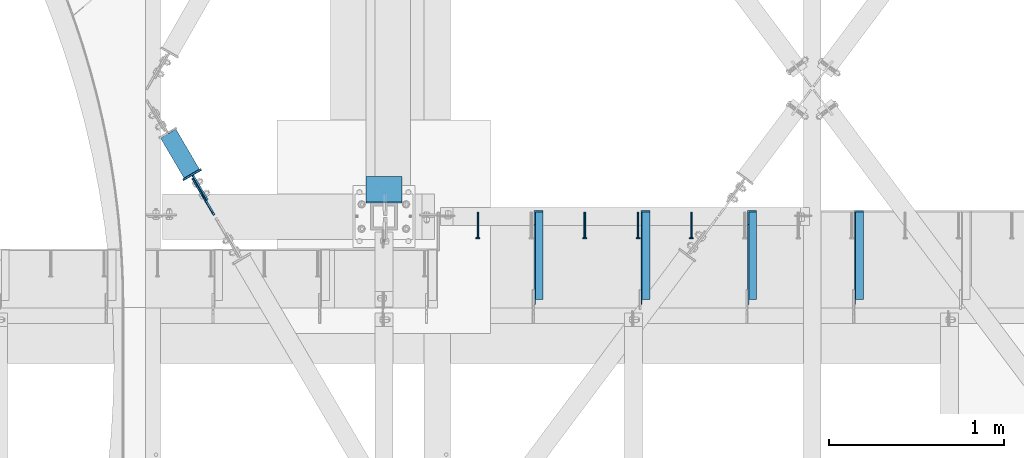
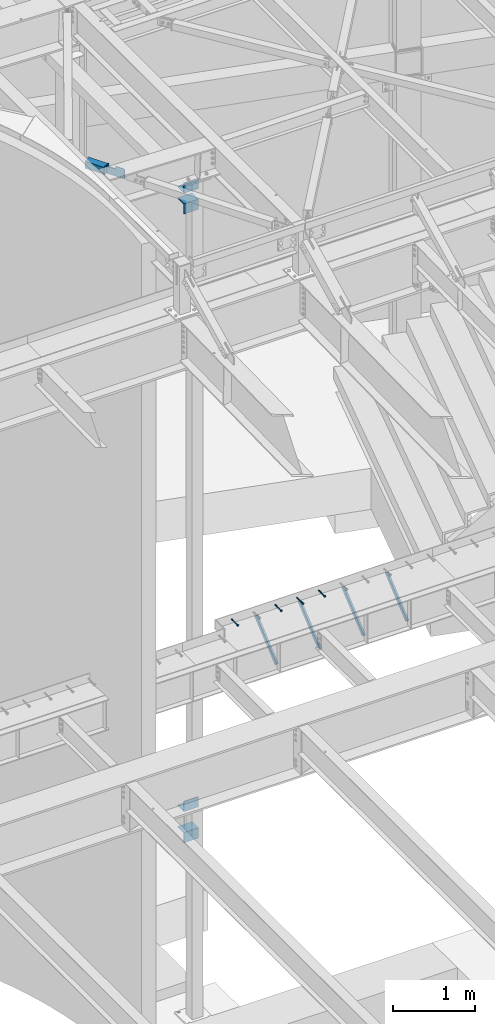
# One storey, part 1361 of 1763: 9 beams, 7 members, 8 elements without a shape of their own.
"""IFC2X3 building model written with IfcOpenShell, lengths in millimetres."""

import ifcopenshell
import ifcopenshell.guid

model = None  # the IFC model being written
_history = None  # IfcOwnerHistory: only IFC2X3 demands one
_inside = {}  # id of a spatial element -> (the spatial element, [elements in it])
_under = {}  # id of a project, library or spatial element -> (it, [spatial elements below it])
_declared = {}  # id of a project -> (the project, [libraries it declares])
_typed = {}  # id of a type object -> (the type object, [elements of that type])
_made_of = {}  # id of a material, layer set ... -> (it, [elements and type objects made of it])


def new_model(schema):
    """Start an empty IFC model of exactly this schema.

    Asked for "IFC4X3", IfcOpenShell would pick the latest addendum, in which some entities
    have other attributes; the version numbers below select the first issue.
    IFC2X3 requires an IfcOwnerHistory on every rooted entity: one is made here for all.
    """
    global model, _history
    if schema == "IFC4X3":
        model = ifcopenshell.file(schema_version=(4, 3, 0, 0))
    else:
        model = ifcopenshell.file(schema=schema)
    _inside.clear()
    _under.clear()
    _declared.clear()
    _typed.clear()
    _made_of.clear()
    _history = None
    if model.schema == "IFC2X3":
        org = make("IfcOrganization", Name="unknown")
        user = make(
            "IfcPersonAndOrganization",
            ThePerson=make("IfcPerson", FamilyName="unknown"),
            TheOrganization=org,
        )
        app = make(
            "IfcApplication",
            ApplicationDeveloper=org,
            Version="unknown",
            ApplicationFullName="unknown",
            ApplicationIdentifier="unknown",
        )
        _history = make(
            "IfcOwnerHistory",
            OwningUser=user,
            OwningApplication=app,
            ChangeAction="ADDED",
            CreationDate=0,
        )
    return model


def make(cls, **values):
    """One entity of the class cls with the attributes given. An attribute that is None is left unset."""
    return model.create_entity(
        cls, **{name: value for name, value in values.items() if value is not None}
    )


def rooted(cls, **values):
    """An entity with a GlobalId (a new one), such as an element, a storey or a relation."""
    return make(cls, GlobalId=ifcopenshell.guid.new(), OwnerHistory=_history, **values)


def si_unit(unit_type, name, prefix=None):
    """IfcSIUnit, for example si_unit("LENGTHUNIT", "METRE", prefix="MILLI")."""
    return make("IfcSIUnit", UnitType=unit_type, Prefix=prefix, Name=name)


def assignment(units):
    """IfcUnitAssignment: the units of a project."""
    return None if units is None else make("IfcUnitAssignment", Units=units)


def point(xyz):
    """IfcCartesianPoint."""
    return None if xyz is None else make("IfcCartesianPoint", Coordinates=xyz)


def direction(xyz):
    """IfcDirection."""
    return None if xyz is None else make("IfcDirection", DirectionRatios=xyz)


def frame(location, z_axis=None, x_axis=None):
    """IfcAxis2Placement3D, a coordinate frame: its origin and axes. An axis left out is left unset."""
    return make(
        "IfcAxis2Placement3D",
        Location=point(location),
        Axis=direction(z_axis),
        RefDirection=direction(x_axis),
    )


def origin_with_axes():
    """The frame at (0, 0, 0) with the z axis (0, 0, 1) and the x axis (1, 0, 0) written out."""
    return frame((0.0, 0.0, 0.0), z_axis=(0.0, 0.0, 1.0), x_axis=(1.0, 0.0, 0.0))


def place(relative_to, where):
    """IfcLocalPlacement: puts the frame where relative to a parent placement (None: the world)."""
    return make(
        "IfcLocalPlacement", PlacementRelTo=relative_to, RelativePlacement=where
    )


def context(
    kind, dimensions, precision=None, world=None, true_north=None, identifier=None
):
    """IfcGeometricRepresentationContext, for example the 3D "Model" context."""
    return make(
        "IfcGeometricRepresentationContext",
        ContextIdentifier=identifier,
        ContextType=kind,
        CoordinateSpaceDimension=dimensions,
        Precision=precision,
        WorldCoordinateSystem=world,
        TrueNorth=true_north,
    )


def subcontext(parent, identifier, kind, view, scale=None):
    """IfcGeometricRepresentationSubContext, for example "Body" below "Model"."""
    return make(
        "IfcGeometricRepresentationSubContext",
        ContextIdentifier=identifier,
        ContextType=kind,
        ParentContext=parent,
        TargetScale=scale,
        TargetView=view,
    )


def project(units=None, contexts=None):
    """IfcProject with its units and contexts."""
    return rooted(
        "IfcProject",
        Name="project",
        RepresentationContexts=contexts,
        UnitsInContext=assignment(units),
    )


def spatial(cls, under=None, at=None, **own):
    """A site, building, storey or space (cls), placed at a placement, below another one or the project."""
    s = rooted(cls, ObjectPlacement=at, **own)
    if under is not None:
        _under.setdefault(under.id(), (under, []))[1].append(s)
    return s


def faces_of(points, faces, orient=None, outer=None):
    """IfcFace entities. A face is a list of loops; a loop is a list of indices into points, from 0.

    orient and outer hold one flag for each loop. By default every Orientation is true, the
    first loop of a face is its IfcFaceOuterBound and the others are IfcFaceBound.
    """
    made = []
    for i, loops in enumerate(faces):
        bounds = []
        for j, loop in enumerate(loops):
            is_outer = j == 0 if outer is None else outer[i][j]
            bounds.append(
                make(
                    "IfcFaceOuterBound" if is_outer else "IfcFaceBound",
                    Bound=make("IfcPolyLoop", Polygon=[points[k] for k in loop]),
                    Orientation=True if orient is None else orient[i][j],
                )
            )
        made.append(make("IfcFace", Bounds=bounds))
    return made


def faceted_brep(points, faces, orient=None, outer=None, voids=None):
    """IfcFacetedBrep: a solid bounded by flat faces; with voids (closed shells), ...WithVoids."""
    shared = [point(p) for p in points]
    hull = make("IfcClosedShell", CfsFaces=faces_of(shared, faces, orient, outer))
    if voids is None:
        return make("IfcFacetedBrep", Outer=hull)
    return make(
        "IfcFacetedBrepWithVoids",
        Outer=hull,
        Voids=[
            make(cls, CfsFaces=faces_of(shared, fs, o, b)) for cls, fs, o, b in voids
        ],
    )


def shape(context_of_items, identifier, shape_type, items):
    """IfcShapeRepresentation: the items that make up one representation, for example the "Body"."""
    return make(
        "IfcShapeRepresentation",
        ContextOfItems=context_of_items,
        RepresentationIdentifier=identifier,
        RepresentationType=shape_type,
        Items=items,
    )


def material(Name=None, Category=None):
    """IfcMaterial."""
    return make("IfcMaterial", Name=Name, Category=Category)


def made_of(thing, what):
    """Note that an element or type object is made of a material, layer set ...; save() writes the relation."""
    if what is not None:
        _made_of.setdefault(what.id(), (what, []))[1].append(thing)
    return thing


def type_object(cls, material=None, **own):
    """A type object (cls), such as IfcWallType, which elements share."""
    return made_of(rooted(cls, **own), material)


def element(
    cls,
    number,
    at=None,
    inside=None,
    cuts=None,
    type_object=None,
    material=None,
    context=None,
    identifier="Body",
    shape_type=None,
    held_by="IfcProductDefinitionShape",
    body=None,
    shapes=None,
    **own,
):
    """One element of the class cls, such as IfcWall. Its Tag is "e" and its number.

    at: its placement. inside: the storey or other place that contains it. cuts: it is an
    opening in that element (IfcRelVoidsElement). A single representation is given by context,
    identifier, shape_type and body (its items); several are given by shapes. held_by: the class
    of the entity that holds the representations. save() writes the other relations.
    """
    e = rooted(cls, Tag="e%d" % number, ObjectPlacement=at, **own)
    if body is not None:
        shapes = [shape(context, identifier, shape_type, body)]
    if shapes is not None:
        e.Representation = make(held_by, Representations=shapes)
    if inside is not None:
        _inside.setdefault(inside.id(), (inside, []))[1].append(e)
    if cuts is not None:
        rooted(
            "IfcRelVoidsElement", RelatingBuildingElement=cuts, RelatedOpeningElement=e
        )
    if type_object is not None:
        _typed.setdefault(type_object.id(), (type_object, []))[1].append(e)
    return made_of(e, material)


def aggregate(whole, parts):
    """IfcRelAggregates: a whole, such as a stair, and the parts it consists of."""
    return rooted("IfcRelAggregates", RelatingObject=whole, RelatedObjects=parts)


def save(model, path):
    """Write the relations noted so far, then the file.

    IfcRelAggregates (storeys below a building ...), IfcRelContainedInSpatialStructure (elements
    in a storey), IfcRelDefinesByType, IfcRelAssociatesMaterial and IfcRelDeclares: one each for
    every whole, place, type object, material and project.
    """
    for whole, parts in _under.values():
        aggregate(whole, parts)
    for where, things in _inside.values():
        rooted(
            "IfcRelContainedInSpatialStructure",
            RelatedElements=things,
            RelatingStructure=where,
        )
    for kind, things in _typed.values():
        rooted("IfcRelDefinesByType", RelatedObjects=things, RelatingType=kind)
    for what, things in _made_of.values():
        rooted("IfcRelAssociatesMaterial", RelatedObjects=things, RelatingMaterial=what)
    for by, libraries in _declared.values():
        rooted("IfcRelDeclares", RelatingContext=by, RelatedDefinitions=libraries)
    model.write(path)


model = new_model("IFC2X3")

# Units and contexts
model_context = context("Model", 3, precision=1e-05, world=origin_with_axes())
body_context = subcontext(model_context, "Body", "Model", "MODEL_VIEW")
ifc_project = project(units=[si_unit("LENGTHUNIT", "METRE", prefix="MILLI"), si_unit("AREAUNIT", "SQUARE_METRE"), si_unit("VOLUMEUNIT", "CUBIC_METRE"), si_unit("MASSUNIT", "GRAM", prefix="KILO"), si_unit("TIMEUNIT", "SECOND"), si_unit("PLANEANGLEUNIT", "RADIAN"), si_unit("SOLIDANGLEUNIT", "STERADIAN"), si_unit("THERMODYNAMICTEMPERATUREUNIT", "DEGREE_CELSIUS"), si_unit("LUMINOUSINTENSITYUNIT", "LUMEN")], contexts=[model_context])

# Site, building, storey
site_placement = place(None, origin_with_axes())
site = spatial("IfcSite", under=ifc_project, at=site_placement, CompositionType="ELEMENT")
building_placement = place(site_placement, origin_with_axes())
building = spatial("IfcBuilding", under=site, at=building_placement, Name="Undefined", CompositionType="ELEMENT")
storey_placement = place(building_placement, origin_with_axes())
storey = spatial("IfcBuildingStorey", under=building, at=storey_placement, Name="Undefined", CompositionType="ELEMENT", Elevation=0.0)

# Assembly, beam
assembly_1_placement = place(storey_placement, origin_with_axes())
assembly_1 = element("IfcElementAssembly", 1, at=assembly_1_placement, inside=storey, Name="HEADED STUD ANCHOR", AssemblyPlace="NOTDEFINED", PredefinedType="RIGID_FRAME")
ifc_material_1 = material(Name="STEEL/A108")
beam_type_1 = type_object("IfcBeamType", PredefinedType="NOTDEFINED")
beam_1_placement = place(assembly_1_placement, frame((-38221.6747736983, 54203.6, 5264.23140606069), z_axis=(0.0, 0.0, 1.0), x_axis=(0.0, -1.0, 0.0)))
beam_1 = element("IfcBeam", 2, at=beam_1_placement, type_object=beam_type_1, material=ifc_material_1, Name="HEADED STUD ANCHOR", context=body_context, shape_type="Brep", body=[
    faceted_brep([(0.0, -3.1800000667572, 5.5), (0.0, -5.5, 3.1800000667572), (141.732000000002, -5.5, 3.1800000667572), (141.732000000002, -3.1800000667572, 5.5), (0.0, -6.34999999999491, 1.45519152283669e-11), (141.732000000002, -6.34999990463257, 0.0), (0.0, -5.5, -3.1800000667572), (141.732000000002, -5.5, -3.1800000667572), (0.0, -3.1800000667572, -5.5), (141.732000000002, -3.1800000667572, -5.5), (0.0, 0.0, -6.34999990463257), (141.732000000002, 0.0, -6.34999990463257), (0.0, 3.1800000667572, -5.5), (141.732000000002, 3.1800000667572, -5.5), (0.0, 5.5, -3.1800000667572), (141.732000000002, 5.5, -3.1800000667572), (0.0, 6.34999999999491, -2.91038304567337e-11), (141.732000000002, 6.34999990463257, 0.0), (0.0, 5.5, 3.1800000667572), (141.732000000002, 5.5, 3.1800000667572), (0.0, 3.1800000667572, 5.5), (141.732000000002, 3.1800000667572, 5.5), (0.0, 0.0, 6.34999990463257), (141.732000000002, 0.0, 6.34999990463257), (144.780000000001, -10.9899997711182, 6.34999990463257), (144.780000000001, -6.34000015258789, 10.9899997711182), (144.780000000001, -12.6999998092651, 0.0), (144.780000000001, -10.9899997711182, -6.34999990463257), (144.780000000001, -6.34000015258789, -10.9899997711182), (144.780000000001, 0.0, -12.6899995803833), (144.780000000001, 6.34000015258789, -10.9899997711182), (144.780000000001, 10.9899997711182, -6.34999990463257), (144.780000000001, 12.6999998092651, 0.0), (144.780000000001, 10.9899997711182, 6.34999990463257), (144.780000000001, 6.34000015258789, 10.9899997711182), (144.780000000001, 0.0, 12.6899995803833), (152.400000000001, -10.9899997711182, 6.34999990463257), (152.400000000001, -6.34000015258789, 10.9899997711182), (152.400000000001, -12.6999998092651, 0.0), (152.400000000001, -10.9899997711182, -6.34999990463257), (152.400000000001, -6.34000015258789, -10.9899997711182), (152.400000000001, 0.0, -12.6899995803833), (152.400000000001, 6.34000015258789, -10.9899997711182), (152.400000000001, 10.9899997711182, -6.34999990463257), (152.400000000001, 12.6999998092651, 0.0), (152.400000000001, 10.9899997711182, 6.34999990463257), (152.400000000001, 6.34000015258789, 10.9899997711182), (152.400000000001, 0.0, 12.6899995803833)], [[[0, 1, 2, 3]], [[1, 4, 5, 2]], [[4, 6, 7, 5]], [[6, 8, 9, 7]], [[8, 10, 11, 9]], [[10, 12, 13, 11]], [[12, 14, 15, 13]], [[14, 16, 17, 15]], [[16, 18, 19, 17]], [[18, 20, 21, 19]], [[20, 22, 23, 21]], [[22, 0, 3, 23]], [[22, 20, 18, 16, 14, 12, 10, 8, 6, 4, 1, 0]], [[3, 2, 24, 25]], [[2, 5, 26, 24]], [[5, 7, 27, 26]], [[7, 9, 28, 27]], [[9, 11, 29, 28]], [[11, 13, 30, 29]], [[13, 15, 31, 30]], [[15, 17, 32, 31]], [[17, 19, 33, 32]], [[19, 21, 34, 33]], [[21, 23, 35, 34]], [[23, 3, 25, 35]], [[25, 24, 36, 37]], [[24, 26, 38, 36]], [[26, 27, 39, 38]], [[27, 28, 40, 39]], [[28, 29, 41, 40]], [[29, 30, 42, 41]], [[30, 31, 43, 42]], [[31, 32, 44, 43]], [[32, 33, 45, 44]], [[33, 34, 46, 45]], [[34, 35, 47, 46]], [[35, 25, 37, 47]], [[38, 39, 40, 41, 42, 43, 44, 45, 46, 47, 37, 36]]]),
])
aggregate(assembly_1, [beam_1])

assembly_2_placement = place(storey_placement, origin_with_axes())
assembly_2 = element("IfcElementAssembly", 3, at=assembly_2_placement, inside=storey, Name="HEADED STUD ANCHOR", AssemblyPlace="NOTDEFINED", PredefinedType="RIGID_FRAME")
beam_2_placement = place(assembly_2_placement, frame((-38526.4747736983, 54203.6, 5264.23140606069), z_axis=(0.0, 0.0, 1.0), x_axis=(0.0, -1.0, 0.0)))
beam_2 = element("IfcBeam", 4, at=beam_2_placement, type_object=beam_type_1, material=ifc_material_1, Name="HEADED STUD ANCHOR", context=body_context, shape_type="Brep", body=[
    faceted_brep([(0.0, -3.1800000667572, 5.5), (0.0, -5.5, 3.1800000667572), (141.732000000002, -5.5, 3.1800000667572), (141.732000000002, -3.1800000667572, 5.5), (0.0, -6.34999999999491, 1.45519152283669e-11), (141.732000000002, -6.34999990463257, 0.0), (0.0, -5.5, -3.1800000667572), (141.732000000002, -5.5, -3.1800000667572), (0.0, -3.1800000667572, -5.5), (141.732000000002, -3.1800000667572, -5.5), (0.0, 0.0, -6.34999990463257), (141.732000000002, 0.0, -6.34999990463257), (0.0, 3.1800000667572, -5.5), (141.732000000002, 3.1800000667572, -5.5), (0.0, 5.5, -3.1800000667572), (141.732000000002, 5.5, -3.1800000667572), (0.0, 6.34999999999491, -2.91038304567337e-11), (141.732000000002, 6.34999990463257, 0.0), (0.0, 5.5, 3.1800000667572), (141.732000000002, 5.5, 3.1800000667572), (0.0, 3.1800000667572, 5.5), (141.732000000002, 3.1800000667572, 5.5), (0.0, 0.0, 6.34999990463257), (141.732000000002, 0.0, 6.34999990463257), (144.780000000001, -10.9899997711182, 6.34999990463257), (144.780000000001, -6.34000015258789, 10.9899997711182), (144.780000000001, -12.6999998092651, 0.0), (144.780000000001, -10.9899997711182, -6.34999990463257), (144.780000000001, -6.34000015258789, -10.9899997711182), (144.780000000001, 0.0, -12.6899995803833), (144.780000000001, 6.34000015258789, -10.9899997711182), (144.780000000001, 10.9899997711182, -6.34999990463257), (144.780000000001, 12.6999998092651, 0.0), (144.780000000001, 10.9899997711182, 6.34999990463257), (144.780000000001, 6.34000015258789, 10.9899997711182), (144.780000000001, 0.0, 12.6899995803833), (152.400000000001, -10.9899997711182, 6.34999990463257), (152.400000000001, -6.34000015258789, 10.9899997711182), (152.400000000001, -12.6999998092651, 0.0), (152.400000000001, -10.9899997711182, -6.34999990463257), (152.400000000001, -6.34000015258789, -10.9899997711182), (152.400000000001, 0.0, -12.6899995803833), (152.400000000001, 6.34000015258789, -10.9899997711182), (152.400000000001, 10.9899997711182, -6.34999990463257), (152.400000000001, 12.6999998092651, 0.0), (152.400000000001, 10.9899997711182, 6.34999990463257), (152.400000000001, 6.34000015258789, 10.9899997711182), (152.400000000001, 0.0, 12.6899995803833)], [[[0, 1, 2, 3]], [[1, 4, 5, 2]], [[4, 6, 7, 5]], [[6, 8, 9, 7]], [[8, 10, 11, 9]], [[10, 12, 13, 11]], [[12, 14, 15, 13]], [[14, 16, 17, 15]], [[16, 18, 19, 17]], [[18, 20, 21, 19]], [[20, 22, 23, 21]], [[22, 0, 3, 23]], [[22, 20, 18, 16, 14, 12, 10, 8, 6, 4, 1, 0]], [[3, 2, 24, 25]], [[2, 5, 26, 24]], [[5, 7, 27, 26]], [[7, 9, 28, 27]], [[9, 11, 29, 28]], [[11, 13, 30, 29]], [[13, 15, 31, 30]], [[15, 17, 32, 31]], [[17, 19, 33, 32]], [[19, 21, 34, 33]], [[21, 23, 35, 34]], [[23, 3, 25, 35]], [[25, 24, 36, 37]], [[24, 26, 38, 36]], [[26, 27, 39, 38]], [[27, 28, 40, 39]], [[28, 29, 41, 40]], [[29, 30, 42, 41]], [[30, 31, 43, 42]], [[31, 32, 44, 43]], [[32, 33, 45, 44]], [[33, 34, 46, 45]], [[34, 35, 47, 46]], [[35, 25, 37, 47]], [[38, 39, 40, 41, 42, 43, 44, 45, 46, 47, 37, 36]]]),
])
aggregate(assembly_2, [beam_2])

assembly_3_placement = place(storey_placement, origin_with_axes())
assembly_3 = element("IfcElementAssembly", 5, at=assembly_3_placement, inside=storey, Name="HEADED STUD ANCHOR", AssemblyPlace="NOTDEFINED", PredefinedType="RIGID_FRAME")
beam_3_placement = place(assembly_3_placement, frame((-38831.2747736983, 54203.6, 5264.23140606069), z_axis=(0.0, 0.0, 1.0), x_axis=(0.0, -1.0, 0.0)))
beam_3 = element("IfcBeam", 6, at=beam_3_placement, type_object=beam_type_1, material=ifc_material_1, Name="HEADED STUD ANCHOR", context=body_context, shape_type="Brep", body=[
    faceted_brep([(0.0, -3.1800000667572, 5.5), (0.0, -5.5, 3.1800000667572), (141.732000000002, -5.5, 3.1800000667572), (141.732000000002, -3.1800000667572, 5.5), (0.0, -6.34999999999491, 1.45519152283669e-11), (141.732000000002, -6.34999990463257, 0.0), (0.0, -5.5, -3.1800000667572), (141.732000000002, -5.5, -3.1800000667572), (0.0, -3.1800000667572, -5.5), (141.732000000002, -3.1800000667572, -5.5), (0.0, 0.0, -6.34999990463257), (141.732000000002, 0.0, -6.34999990463257), (0.0, 3.1800000667572, -5.5), (141.732000000002, 3.1800000667572, -5.5), (0.0, 5.5, -3.1800000667572), (141.732000000002, 5.5, -3.1800000667572), (0.0, 6.34999999999491, -2.91038304567337e-11), (141.732000000002, 6.34999990463257, 0.0), (0.0, 5.5, 3.1800000667572), (141.732000000002, 5.5, 3.1800000667572), (0.0, 3.1800000667572, 5.5), (141.732000000002, 3.1800000667572, 5.5), (0.0, 0.0, 6.34999990463257), (141.732000000002, 0.0, 6.34999990463257), (144.780000000001, -10.9899997711182, 6.34999990463257), (144.780000000001, -6.34000015258789, 10.9899997711182), (144.780000000001, -12.6999998092651, 0.0), (144.780000000001, -10.9899997711182, -6.34999990463257), (144.780000000001, -6.34000015258789, -10.9899997711182), (144.780000000001, 0.0, -12.6899995803833), (144.780000000001, 6.34000015258789, -10.9899997711182), (144.780000000001, 10.9899997711182, -6.34999990463257), (144.780000000001, 12.6999998092651, 0.0), (144.780000000001, 10.9899997711182, 6.34999990463257), (144.780000000001, 6.34000015258789, 10.9899997711182), (144.780000000001, 0.0, 12.6899995803833), (152.400000000001, -10.9899997711182, 6.34999990463257), (152.400000000001, -6.34000015258789, 10.9899997711182), (152.400000000001, -12.6999998092651, 0.0), (152.400000000001, -10.9899997711182, -6.34999990463257), (152.400000000001, -6.34000015258789, -10.9899997711182), (152.400000000001, 0.0, -12.6899995803833), (152.400000000001, 6.34000015258789, -10.9899997711182), (152.400000000001, 10.9899997711182, -6.34999990463257), (152.400000000001, 12.6999998092651, 0.0), (152.400000000001, 10.9899997711182, 6.34999990463257), (152.400000000001, 6.34000015258789, 10.9899997711182), (152.400000000001, 0.0, 12.6899995803833)], [[[0, 1, 2, 3]], [[1, 4, 5, 2]], [[4, 6, 7, 5]], [[6, 8, 9, 7]], [[8, 10, 11, 9]], [[10, 12, 13, 11]], [[12, 14, 15, 13]], [[14, 16, 17, 15]], [[16, 18, 19, 17]], [[18, 20, 21, 19]], [[20, 22, 23, 21]], [[22, 0, 3, 23]], [[22, 20, 18, 16, 14, 12, 10, 8, 6, 4, 1, 0]], [[3, 2, 24, 25]], [[2, 5, 26, 24]], [[5, 7, 27, 26]], [[7, 9, 28, 27]], [[9, 11, 29, 28]], [[11, 13, 30, 29]], [[13, 15, 31, 30]], [[15, 17, 32, 31]], [[17, 19, 33, 32]], [[19, 21, 34, 33]], [[21, 23, 35, 34]], [[23, 3, 25, 35]], [[25, 24, 36, 37]], [[24, 26, 38, 36]], [[26, 27, 39, 38]], [[27, 28, 40, 39]], [[28, 29, 41, 40]], [[29, 30, 42, 41]], [[30, 31, 43, 42]], [[31, 32, 44, 43]], [[32, 33, 45, 44]], [[33, 34, 46, 45]], [[34, 35, 47, 46]], [[35, 25, 37, 47]], [[38, 39, 40, 41, 42, 43, 44, 45, 46, 47, 37, 36]]]),
])
aggregate(assembly_3, [beam_3])

assembly_4_placement = place(storey_placement, origin_with_axes())
assembly_4 = element("IfcElementAssembly", 7, at=assembly_4_placement, inside=storey, Name="HEADED STUD ANCHOR", AssemblyPlace="NOTDEFINED", PredefinedType="RIGID_FRAME")
beam_4_placement = place(assembly_4_placement, frame((-39440.8747736983, 54203.6, 5264.23140606069), z_axis=(0.0, 0.0, 1.0), x_axis=(0.0, -1.0, 0.0)))
beam_4 = element("IfcBeam", 8, at=beam_4_placement, type_object=beam_type_1, material=ifc_material_1, Name="HEADED STUD ANCHOR", context=body_context, shape_type="Brep", body=[
    faceted_brep([(0.0, -3.1800000667572, 5.5), (0.0, -5.5, 3.1800000667572), (141.732000000002, -5.5, 3.1800000667572), (141.732000000002, -3.1800000667572, 5.5), (0.0, -6.34999999999491, 1.45519152283669e-11), (141.732000000002, -6.34999990463257, 0.0), (0.0, -5.5, -3.1800000667572), (141.732000000002, -5.5, -3.1800000667572), (0.0, -3.1800000667572, -5.5), (141.732000000002, -3.1800000667572, -5.5), (0.0, 0.0, -6.34999990463257), (141.732000000002, 0.0, -6.34999990463257), (0.0, 3.1800000667572, -5.5), (141.732000000002, 3.1800000667572, -5.5), (0.0, 5.5, -3.1800000667572), (141.732000000002, 5.5, -3.1800000667572), (0.0, 6.34999999999491, -2.91038304567337e-11), (141.732000000002, 6.34999990463257, 0.0), (0.0, 5.5, 3.1800000667572), (141.732000000002, 5.5, 3.1800000667572), (0.0, 3.1800000667572, 5.5), (141.732000000002, 3.1800000667572, 5.5), (0.0, 0.0, 6.34999990463257), (141.732000000002, 0.0, 6.34999990463257), (144.780000000001, -10.9899997711182, 6.34999990463257), (144.780000000001, -6.34000015258789, 10.9899997711182), (144.780000000001, -12.6999998092651, 0.0), (144.780000000001, -10.9899997711182, -6.34999990463257), (144.780000000001, -6.34000015258789, -10.9899997711182), (144.780000000001, 0.0, -12.6899995803833), (144.780000000001, 6.34000015258789, -10.9899997711182), (144.780000000001, 10.9899997711182, -6.34999990463257), (144.780000000001, 12.6999998092651, 0.0), (144.780000000001, 10.9899997711182, 6.34999990463257), (144.780000000001, 6.34000015258789, 10.9899997711182), (144.780000000001, 0.0, 12.6899995803833), (152.400000000001, -10.9899997711182, 6.34999990463257), (152.400000000001, -6.34000015258789, 10.9899997711182), (152.400000000001, -12.6999998092651, 0.0), (152.400000000001, -10.9899997711182, -6.34999990463257), (152.400000000001, -6.34000015258789, -10.9899997711182), (152.400000000001, 0.0, -12.6899995803833), (152.400000000001, 6.34000015258789, -10.9899997711182), (152.400000000001, 10.9899997711182, -6.34999990463257), (152.400000000001, 12.6999998092651, 0.0), (152.400000000001, 10.9899997711182, 6.34999990463257), (152.400000000001, 6.34000015258789, 10.9899997711182), (152.400000000001, 0.0, 12.6899995803833)], [[[0, 1, 2, 3]], [[1, 4, 5, 2]], [[4, 6, 7, 5]], [[6, 8, 9, 7]], [[8, 10, 11, 9]], [[10, 12, 13, 11]], [[12, 14, 15, 13]], [[14, 16, 17, 15]], [[16, 18, 19, 17]], [[18, 20, 21, 19]], [[20, 22, 23, 21]], [[22, 0, 3, 23]], [[22, 20, 18, 16, 14, 12, 10, 8, 6, 4, 1, 0]], [[3, 2, 24, 25]], [[2, 5, 26, 24]], [[5, 7, 27, 26]], [[7, 9, 28, 27]], [[9, 11, 29, 28]], [[11, 13, 30, 29]], [[13, 15, 31, 30]], [[15, 17, 32, 31]], [[17, 19, 33, 32]], [[19, 21, 34, 33]], [[21, 23, 35, 34]], [[23, 3, 25, 35]], [[25, 24, 36, 37]], [[24, 26, 38, 36]], [[26, 27, 39, 38]], [[27, 28, 40, 39]], [[28, 29, 41, 40]], [[29, 30, 42, 41]], [[30, 31, 43, 42]], [[31, 32, 44, 43]], [[32, 33, 45, 44]], [[33, 34, 46, 45]], [[34, 35, 47, 46]], [[35, 25, 37, 47]], [[38, 39, 40, 41, 42, 43, 44, 45, 46, 47, 37, 36]]]),
])
aggregate(assembly_4, [beam_4])

# Assembly, members
assembly_5_placement = place(storey_placement, origin_with_axes())
assembly_5 = element("IfcElementAssembly", 9, at=assembly_5_placement, inside=storey, Name="BEAM", AssemblyPlace="NOTDEFINED", PredefinedType="RIGID_FRAME")
ifc_material_2 = material(Name="STEEL/A36")
member_type_1 = type_object("IfcMemberType", Name="L2X2X1/4", PredefinedType="NOTDEFINED")
member_1_placement = place(assembly_5_placement, frame((-37265.4044734054, 53692.8752601513, 4792.34833807684), z_axis=(0.0, -0.641507205139845, 0.767117009167223), x_axis=(0.0, 0.767117009167224, 0.641507205139844)))
member_1 = element("IfcMember", 10, at=member_1_placement, type_object=member_type_1, material=ifc_material_2, Name="ANGLE", ObjectType="L2X2X1/4", context=body_context, shape_type="Brep", body=[
    faceted_brep([(-1.45519152283669e-11, 25.4000000000015, -25.3999999999869), (1.45519152283669e-11, 25.4000000000015, 25.3999999999796), (596.200457969971, 25.4000000000015, 25.3999999984771), (656.947310752032, 25.4000000000015, -25.4000000016313), (1.45519152283669e-11, 19.0499999999993, 25.3999999999796), (596.200457969971, 19.0500000000029, 25.3999999984771), (-7.27595761418343e-12, 19.0499999999993, -19.0499999999956), (649.35395415427, 19.0500000000029, -19.0500000016218), (-7.27595761418343e-12, -25.4000000000015, -19.0499999999956), (649.35395415427, -25.4000000000015, -19.0500000016218), (-1.45519152283669e-11, -25.4000000000015, -25.3999999999869), (656.947310752032, -25.4000000000015, -25.4000000016313)], [[[0, 1, 2, 3]], [[1, 4, 5, 2]], [[4, 6, 7, 5]], [[6, 8, 9, 7]], [[8, 10, 11, 9]], [[10, 0, 3, 11]], [[5, 7, 9, 11, 3, 2]], [[10, 8, 6, 4, 1, 0]]]),
])
member_2_placement = place(assembly_5_placement, frame((-37875.0044734054, 53692.8752601513, 4792.34833807684), z_axis=(0.0, -0.641507205139845, 0.767117009167223), x_axis=(0.0, 0.767117009167224, 0.641507205139844)))
member_2 = element("IfcMember", 11, at=member_2_placement, type_object=member_type_1, material=ifc_material_2, Name="ANGLE", ObjectType="L2X2X1/4", context=body_context, shape_type="Brep", body=[
    faceted_brep([(-1.45519152283669e-11, 25.4000000000015, -25.3999999999869), (1.45519152283669e-11, 25.4000000000015, 25.3999999999796), (596.200457969971, 25.4000000000015, 25.3999999984771), (656.947310752032, 25.4000000000015, -25.4000000016313), (1.45519152283669e-11, 19.0499999999993, 25.3999999999796), (596.200457969971, 19.0500000000029, 25.3999999984771), (-7.27595761418343e-12, 19.0499999999993, -19.0499999999956), (649.35395415427, 19.0500000000029, -19.0500000016218), (-7.27595761418343e-12, -25.4000000000015, -19.0499999999956), (649.35395415427, -25.4000000000015, -19.0500000016218), (-1.45519152283669e-11, -25.4000000000015, -25.3999999999869), (656.947310752032, -25.4000000000015, -25.4000000016313)], [[[0, 1, 2, 3]], [[1, 4, 5, 2]], [[4, 6, 7, 5]], [[6, 8, 9, 7]], [[8, 10, 11, 9]], [[10, 0, 3, 11]], [[5, 7, 9, 11, 3, 2]], [[10, 8, 6, 4, 1, 0]]]),
])
member_3_placement = place(assembly_5_placement, frame((-38484.6044734054, 53692.8752601513, 4792.34833807684), z_axis=(0.0, -0.641507205139845, 0.767117009167223), x_axis=(0.0, 0.767117009167224, 0.641507205139844)))
member_3 = element("IfcMember", 12, at=member_3_placement, type_object=member_type_1, material=ifc_material_2, Name="ANGLE", ObjectType="L2X2X1/4", context=body_context, shape_type="Brep", body=[
    faceted_brep([(-1.45519152283669e-11, 25.4000000000015, -25.3999999999869), (1.45519152283669e-11, 25.4000000000015, 25.3999999999796), (596.200457969971, 25.4000000000015, 25.3999999984771), (656.947310752032, 25.4000000000015, -25.4000000016313), (1.45519152283669e-11, 19.0499999999993, 25.3999999999796), (596.200457969971, 19.0500000000029, 25.3999999984771), (-7.27595761418343e-12, 19.0499999999993, -19.0499999999956), (649.35395415427, 19.0500000000029, -19.0500000016218), (-7.27595761418343e-12, -25.4000000000015, -19.0499999999956), (649.35395415427, -25.4000000000015, -19.0500000016218), (-1.45519152283669e-11, -25.4000000000015, -25.3999999999869), (656.947310752032, -25.4000000000015, -25.4000000016313)], [[[0, 1, 2, 3]], [[1, 4, 5, 2]], [[4, 6, 7, 5]], [[6, 8, 9, 7]], [[8, 10, 11, 9]], [[10, 0, 3, 11]], [[5, 7, 9, 11, 3, 2]], [[10, 8, 6, 4, 1, 0]]]),
])
member_4_placement = place(assembly_5_placement, frame((-39094.2044734054, 53692.8752601513, 4792.34833807684), z_axis=(0.0, -0.641507205139845, 0.767117009167223), x_axis=(0.0, 0.767117009167224, 0.641507205139844)))
member_4 = element("IfcMember", 13, at=member_4_placement, type_object=member_type_1, material=ifc_material_2, Name="ANGLE", ObjectType="L2X2X1/4", context=body_context, shape_type="Brep", body=[
    faceted_brep([(-1.45519152283669e-11, 25.4000000000015, -25.3999999999869), (1.45519152283669e-11, 25.4000000000015, 25.3999999999796), (596.200457969971, 25.4000000000015, 25.3999999984771), (656.947310752032, 25.4000000000015, -25.4000000016313), (1.45519152283669e-11, 19.0499999999993, 25.3999999999796), (596.200457969971, 19.0500000000029, 25.3999999984771), (-7.27595761418343e-12, 19.0499999999993, -19.0499999999956), (649.35395415427, 19.0500000000029, -19.0500000016218), (-7.27595761418343e-12, -25.4000000000015, -19.0499999999956), (649.35395415427, -25.4000000000015, -19.0500000016218), (-1.45519152283669e-11, -25.4000000000015, -25.3999999999869), (656.947310752032, -25.4000000000015, -25.4000000016313)], [[[0, 1, 2, 3]], [[1, 4, 5, 2]], [[4, 6, 7, 5]], [[6, 8, 9, 7]], [[8, 10, 11, 9]], [[10, 0, 3, 11]], [[5, 7, 9, 11, 3, 2]], [[10, 8, 6, 4, 1, 0]]]),
])
aggregate(assembly_5, [member_1, member_2, member_3, member_4])

# Assembly, beam
assembly_6_placement = place(storey_placement, origin_with_axes())
assembly_6 = element("IfcElementAssembly", 14, at=assembly_6_placement, inside=storey, Name="H. BRACE", AssemblyPlace="NOTDEFINED", PredefinedType="RIGID_FRAME")
ifc_material_3 = material()
beam_type_2 = type_object("IfcBeamType", Name="HSS4X4X3/8", PredefinedType="NOTDEFINED")
beam_5_placement = place(assembly_6_placement, frame((-40896.9450050266, 54121.0500000333, 12371.2888357988), z_axis=(0.0, 0.0, 1.0), x_axis=(-0.506135019889158, 0.862454254811118, 0.0)))
beam_5 = element("IfcBeam", 15, at=beam_5_placement, type_object=beam_type_2, material=ifc_material_3, Name="H. BRACE", ObjectType="HSS4X4X3/8", context=body_context, shape_type="Brep", body=[
    faceted_brep([(349.373870100069, 41.2749999994903, -41.2749999999996), (349.373870097013, -41.2750000006363, -41.2749999999996), (615.38302959947, -41.2750000010692, -41.2749999999996), (615.38302959947, 41.2749999990538, -41.2749999999996), (349.373870108218, -41.275000000629, 41.2749999999996), (615.38302959947, -41.2750000010692, 41.2749999999996), (349.373870111274, 41.274999999483, 41.2749999999996), (615.38302959947, 41.2749999990538, 41.2749999999996), (349.373870099138, 50.7999999994991, -50.7999999999993), (349.373870112919, 50.7999999994954, 50.7999999999993), (615.38302959947, 50.7999999990589, 50.7999999999993), (615.38302959947, 50.7999999990589, -50.7999999999993), (349.373870109164, -50.8000000006487, 50.7999999999993), (615.38302959947, -50.8000000010925, 50.7999999999993), (349.373870095369, -50.8000000006523, -50.7999999999993), (615.38302959947, -50.8000000010925, -50.7999999999993)], [[[0, 1, 2, 3]], [[1, 4, 5, 2]], [[4, 6, 7, 5]], [[6, 0, 3, 7]], [[8, 9, 10, 11]], [[9, 12, 13, 10]], [[12, 14, 15, 13]], [[14, 8, 11, 15]], [[13, 15, 11, 10], [5, 7, 3, 2]], [[14, 12, 9, 8], [6, 4, 1, 0]]]),
])

# Assembly, beams
assembly_7_placement = place(storey_placement, origin_with_axes())
assembly_7 = element("IfcElementAssembly", 16, at=assembly_7_placement, inside=storey, Name="COLUMN", AssemblyPlace="NOTDEFINED", PredefinedType="RIGID_FRAME")
beam_type_3 = type_object("IfcBeamType", Name="L6X6X3/8", PredefinedType="NOTDEFINED")
beam_6_placement = place(assembly_7_placement, frame((-39875.4203125, 54332.2568049484, 2681.2875), z_axis=(0.0, 0.0, 1.0), x_axis=(-1.0, 0.0, 0.0)))
beam_6 = element("IfcBeam", 17, at=beam_6_placement, type_object=beam_type_3, material=ifc_material_2, Name="ANGLE", ObjectType="L6X6X3/8", context=body_context, shape_type="Brep", body=[
    faceted_brep([(9.09494701772928e-13, 76.2000000000007, -76.2000000000844), (0.0, 76.2000000000007, 76.2000000000771), (203.199999999997, 76.1999999999971, 76.2000000000007), (203.199999999997, 76.1999999999971, -76.2000000000007), (0.0, 66.6749999999993, 76.2000000000007), (203.199999999997, 66.6750000000029, 76.2000000000007), (0.0, 66.6749999999993, -66.6749999999993), (203.199999999997, 66.6750000000029, -66.6749999999993), (0.0, -76.2000000000007, -66.6749999999993), (203.199999999997, -76.1999999999971, -66.6749999999993), (9.09494701772928e-13, -76.2000000000007, -76.2000000000844), (203.199999999997, -76.1999999999971, -76.2000000000007)], [[[0, 1, 2, 3]], [[1, 4, 5, 2]], [[4, 6, 7, 5]], [[6, 8, 9, 7]], [[8, 10, 11, 9]], [[10, 0, 3, 11]], [[5, 7, 9, 11, 3, 2]], [[10, 8, 6, 4, 1, 0]]]),
])
beam_7_placement = place(assembly_7_placement, frame((-40078.6203125, 54330.6693049484, 2220.914), z_axis=(0.0, 0.0, -1.0), x_axis=(1.0, 0.0, 0.0)))
beam_7 = element("IfcBeam", 18, at=beam_7_placement, type_object=beam_type_3, material=ifc_material_2, Name="ANGLE", ObjectType="L6X6X3/8", context=body_context, shape_type="Brep", body=[
    faceted_brep([(9.09494701772928e-13, 76.2000000000007, -76.2000000000844), (0.0, 76.2000000000007, 76.2000000000771), (203.199999999997, 76.1999999999971, 76.2000000000007), (203.199999999997, 76.1999999999971, -76.2000000000007), (0.0, 66.6749999999993, 76.2000000000007), (203.199999999997, 66.6750000000029, 76.2000000000007), (0.0, 66.6749999999993, -66.6749999999993), (203.199999999997, 66.6750000000029, -66.6749999999993), (0.0, -76.2000000000007, -66.6749999999993), (203.199999999997, -76.1999999999971, -66.6749999999993), (9.09494701772928e-13, -76.2000000000007, -76.2000000000844), (203.199999999997, -76.1999999999971, -76.2000000000007)], [[[0, 1, 2, 3]], [[1, 4, 5, 2]], [[4, 6, 7, 5]], [[6, 8, 9, 7]], [[8, 10, 11, 9]], [[10, 0, 3, 11]], [[5, 7, 9, 11, 3, 2]], [[10, 8, 6, 4, 1, 0]]]),
])
beam_8_placement = place(assembly_7_placement, frame((-39875.4203125, 54330.6693049484, 11837.9875), z_axis=(0.0, 0.0, 1.0), x_axis=(-1.0, 0.0, 0.0)))
beam_8 = element("IfcBeam", 19, at=beam_8_placement, type_object=beam_type_3, material=ifc_material_2, Name="ANGLE", ObjectType="L6X6X3/8", context=body_context, shape_type="Brep", body=[
    faceted_brep([(9.09494701772928e-13, 76.2000000000007, -76.2000000000844), (0.0, 76.2000000000007, 76.2000000000771), (203.199999999997, 76.1999999999971, 76.2000000000007), (203.199999999997, 76.1999999999971, -76.2000000000007), (0.0, 66.6749999999993, 76.2000000000007), (203.199999999997, 66.6750000000029, 76.2000000000007), (0.0, 66.6749999999993, -66.6749999999993), (203.199999999997, 66.6750000000029, -66.6749999999993), (0.0, -76.2000000000007, -66.6749999999993), (203.199999999997, -76.1999999999971, -66.6749999999993), (9.09494701772928e-13, -76.2000000000007, -76.2000000000844), (203.199999999997, -76.1999999999971, -76.2000000000007)], [[[0, 1, 2, 3]], [[1, 4, 5, 2]], [[4, 6, 7, 5]], [[6, 8, 9, 7]], [[8, 10, 11, 9]], [[10, 0, 3, 11]], [[5, 7, 9, 11, 3, 2]], [[10, 8, 6, 4, 1, 0]]]),
])
beam_9_placement = place(assembly_7_placement, frame((-40078.6203125, 54330.6693049484, 11530.0125), z_axis=(0.0, 0.0, -1.0), x_axis=(1.0, 0.0, 0.0)))
beam_9 = element("IfcBeam", 20, at=beam_9_placement, type_object=beam_type_3, material=ifc_material_2, Name="ANGLE", ObjectType="L6X6X3/8", context=body_context, shape_type="Brep", body=[
    faceted_brep([(9.09494701772928e-13, 76.2000000000007, -76.2000000000844), (0.0, 76.2000000000007, 76.2000000000771), (203.199999999997, 76.1999999999971, 76.2000000000007), (203.199999999997, 76.1999999999971, -76.2000000000007), (0.0, 66.6749999999993, 76.2000000000007), (203.199999999997, 66.6750000000029, 76.2000000000007), (0.0, 66.6749999999993, -66.6749999999993), (203.199999999997, 66.6750000000029, -66.6749999999993), (0.0, -76.2000000000007, -66.6749999999993), (203.199999999997, -76.1999999999971, -66.6749999999993), (9.09494701772928e-13, -76.2000000000007, -76.2000000000844), (203.199999999997, -76.1999999999971, -76.2000000000007)], [[[0, 1, 2, 3]], [[1, 4, 5, 2]], [[4, 6, 7, 5]], [[6, 8, 9, 7]], [[8, 10, 11, 9]], [[10, 0, 3, 11]], [[5, 7, 9, 11, 3, 2]], [[10, 8, 6, 4, 1, 0]]]),
])
aggregate(assembly_7, [beam_6, beam_7, beam_8, beam_9])

# Member
member_type_2 = type_object("IfcMemberType", PredefinedType="NOTDEFINED")
member_5_placement = place(assembly_6_placement, frame((-41069.6100196805, 54419.2913943864, 12428.4026024657), z_axis=(0.861907455369217, 0.505814128216675, -0.0356034559469426), x_axis=(-0.0307063520674201, -0.0180201558838308, -0.99936599598177)))
member_5 = element("IfcMember", 21, at=member_5_placement, type_object=member_type_2, material=ifc_material_2, Name="PLATE", context=body_context, shape_type="Brep", body=[
    faceted_brep([(0.0, 4.76249999989523, -57.1500000001702), (0.0, 4.76250000014261, 57.1500000001565), (114.299999999999, 4.76250000014261, 57.1500000001565), (114.299999999999, 4.76249999989523, -57.1500000001702), (0.0, -4.76249999988067, 57.1500000001784), (114.299999999999, -4.76249999988067, 57.1500000001784), (0.0, -4.76250000012806, -57.150000000152), (114.299999999999, -4.76250000012806, -57.150000000152)], [[[0, 1, 2, 3]], [[1, 4, 5, 2]], [[4, 6, 7, 5]], [[6, 0, 3, 7]], [[5, 7, 3, 2]], [[6, 4, 1, 0]]]),
])

member_type_3 = type_object("IfcMemberType", PredefinedType="NOTDEFINED")
member_6_placement = place(assembly_6_placement, frame((-41025.5012352536, 54343.6833268824, 12422.0566283905), z_axis=(0.506135019889179, -0.862454254811106, 0.0), x_axis=(-0.0307063520674201, -0.0180201558838308, -0.99936599598177)))
member_6 = element("IfcMember", 22, at=member_6_placement, type_object=member_type_3, material=ifc_material_2, Name="PLATE", context=body_context, shape_type="Brep", body=[
    faceted_brep([(3.63797880709171e-11, 4.76249999971515, -82.7709999998915), (-4.00177668780088e-11, 4.76250000029358, 82.7709999999061), (101.599999999929, 4.76250000013533, 82.7709999998187), (101.600000000009, 4.76249999955326, -82.7710000000079), (-3.63797880709171e-11, -4.76249999970605, 82.7709999998769), (101.599999999937, -4.76249999987158, 82.7709999997751), (4.36557456851006e-11, -4.76250000028449, -82.7709999999352), (101.600000000013, -4.76250000045002, -82.771000000037)], [[[0, 1, 2, 3]], [[1, 4, 5, 2]], [[4, 6, 7, 5]], [[6, 0, 3, 7]], [[5, 7, 3, 2]], [[6, 4, 1, 0]]]),
])

aggregate(assembly_6, [member_5, member_6, beam_5])

# Assembly, member
assembly_8_placement = place(storey_placement, origin_with_axes())
assembly_8 = element("IfcElementAssembly", 23, at=assembly_8_placement, inside=storey, Name="BEAM", AssemblyPlace="NOTDEFINED", PredefinedType="RIGID_FRAME")
member_type_4 = type_object("IfcMemberType", PredefinedType="NOTDEFINED")
member_7_placement = place(assembly_8_placement, frame((-41006.9057400437, 54293.1894387472, 12465.8535633142), z_axis=(0.506135019889179, -0.862454254811106, 0.0), x_axis=(-0.0215099100025942, -0.0126231840014923, -0.999688941119859)))
member_7 = element("IfcMember", 24, at=member_7_placement, type_object=member_type_4, material=ifc_material_2, Name="PLATE", context=body_context, shape_type="Brep", body=[
    faceted_brep([(7.82165443524718e-11, -4.76250000022446, 103.981500000154), (19.0500000000884, -4.76250000028995, 123.03150000023), (19.0500000000939, 4.76249999970514, 123.031500000201), (8.54925019666553e-11, 4.76249999976335, 103.981500000125), (-7.27595761418343e-12, -4.76249999998072, -5.75149277450691), (0.0, 4.76250000000982, -5.75149277456512), (30.9223711971372, 4.76249999998163, -5.7514927755692), (31.1596650168267, -4.7625000000171, -5.751492775511), (35.75977829976, 4.76249999997162, -6.70823911477055), (35.9970721194513, -4.76250000001528, -6.70823911471234), (39.8683394801901, 4.76249999997617, -9.43432638861123), (40.1056332998796, -4.7625000000171, -9.43432638855302), (42.6290230963477, 4.7624999999789, -13.5190185248939), (42.8663169160354, -4.76250000001164, -13.5190185248211), (43.6258804895369, 4.76249999998345, -18.3468801997951), (43.8631743092265, -4.76249999999709, -18.3468801997369), (44.7257788290535, -4.76249999976062, -123.031499185177), (44.4884850093622, 4.76250000022173, -123.031500000085), (145.03851270939, -4.76250000042273, 123.031500000536), (145.0385127094, 4.76249999956053, 123.031500000492), (145.038512709201, -4.7624999998734, -123.031499999823), (145.03851270921, 4.7625000001135, -123.031499999866)], [[[0, 1, 2, 3]], [[4, 5, 6, 7]], [[7, 6, 8, 9]], [[9, 8, 10, 11]], [[11, 10, 12, 13]], [[13, 12, 14, 15]], [[16, 15, 14, 17]], [[18, 19, 2, 1]], [[18, 20, 21, 19]], [[21, 20, 16, 17]], [[19, 21, 17, 14, 12, 10, 8, 6, 5, 3, 2]], [[5, 4, 0, 3]], [[4, 7, 9, 11, 13, 15, 16, 20, 18, 1, 0]]]),
])
aggregate(assembly_8, [member_7])

save(model, "model.ifc")
